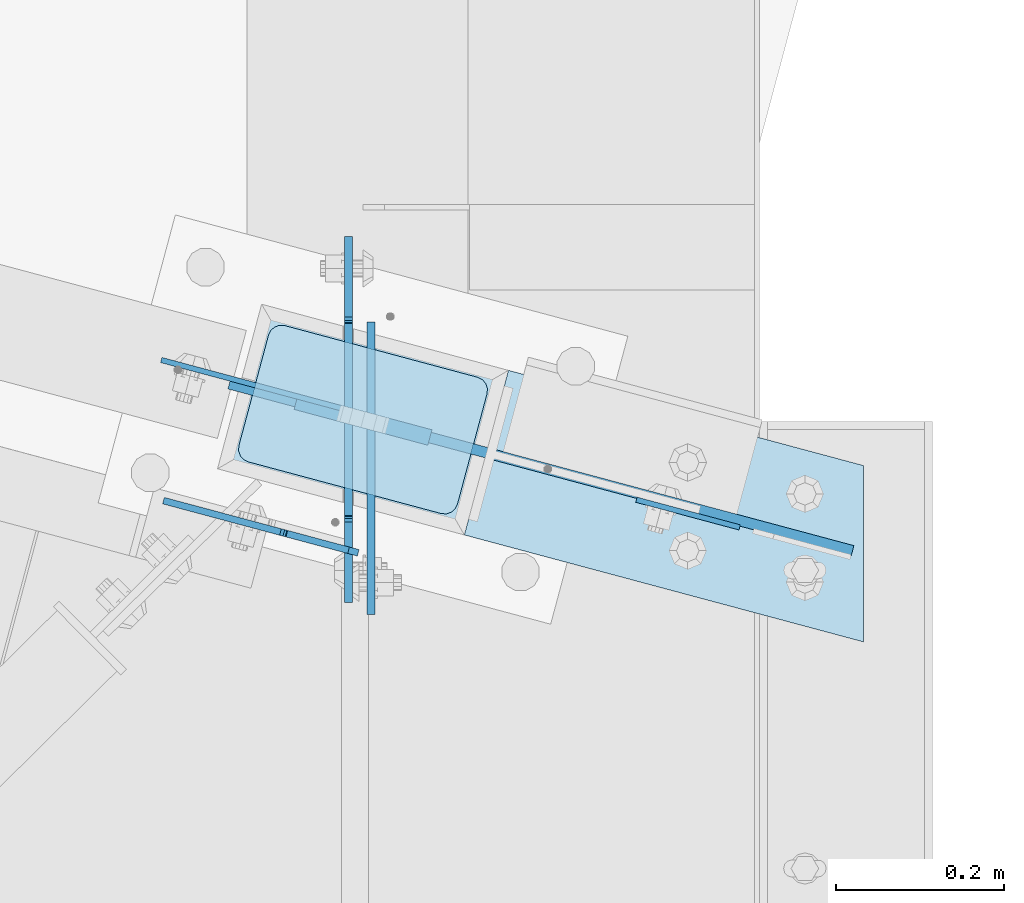
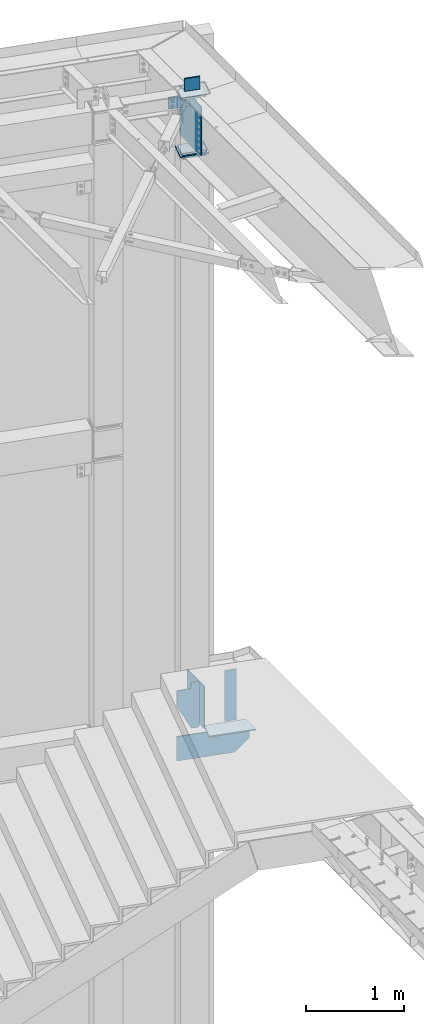
# One storey, part 1700 of 1763: 12 plates, 3 elements without a shape of their own.
"""IFC2X3 building model written with IfcOpenShell, lengths in millimetres."""

import ifcopenshell
import ifcopenshell.guid

model = None  # the IFC model being written
_history = None  # IfcOwnerHistory: only IFC2X3 demands one
_inside = {}  # id of a spatial element -> (the spatial element, [elements in it])
_under = {}  # id of a project, library or spatial element -> (it, [spatial elements below it])
_declared = {}  # id of a project -> (the project, [libraries it declares])
_typed = {}  # id of a type object -> (the type object, [elements of that type])
_made_of = {}  # id of a material, layer set ... -> (it, [elements and type objects made of it])


def new_model(schema):
    """Start an empty IFC model of exactly this schema.

    Asked for "IFC4X3", IfcOpenShell would pick the latest addendum, in which some entities
    have other attributes; the version numbers below select the first issue.
    IFC2X3 requires an IfcOwnerHistory on every rooted entity: one is made here for all.
    """
    global model, _history
    if schema == "IFC4X3":
        model = ifcopenshell.file(schema_version=(4, 3, 0, 0))
    else:
        model = ifcopenshell.file(schema=schema)
    _inside.clear()
    _under.clear()
    _declared.clear()
    _typed.clear()
    _made_of.clear()
    _history = None
    if model.schema == "IFC2X3":
        org = make("IfcOrganization", Name="unknown")
        user = make(
            "IfcPersonAndOrganization",
            ThePerson=make("IfcPerson", FamilyName="unknown"),
            TheOrganization=org,
        )
        app = make(
            "IfcApplication",
            ApplicationDeveloper=org,
            Version="unknown",
            ApplicationFullName="unknown",
            ApplicationIdentifier="unknown",
        )
        _history = make(
            "IfcOwnerHistory",
            OwningUser=user,
            OwningApplication=app,
            ChangeAction="ADDED",
            CreationDate=0,
        )
    return model


def make(cls, **values):
    """One entity of the class cls with the attributes given. An attribute that is None is left unset."""
    return model.create_entity(
        cls, **{name: value for name, value in values.items() if value is not None}
    )


def rooted(cls, **values):
    """An entity with a GlobalId (a new one), such as an element, a storey or a relation."""
    return make(cls, GlobalId=ifcopenshell.guid.new(), OwnerHistory=_history, **values)


def si_unit(unit_type, name, prefix=None):
    """IfcSIUnit, for example si_unit("LENGTHUNIT", "METRE", prefix="MILLI")."""
    return make("IfcSIUnit", UnitType=unit_type, Prefix=prefix, Name=name)


def assignment(units):
    """IfcUnitAssignment: the units of a project."""
    return None if units is None else make("IfcUnitAssignment", Units=units)


def point(xyz):
    """IfcCartesianPoint."""
    return None if xyz is None else make("IfcCartesianPoint", Coordinates=xyz)


def direction(xyz):
    """IfcDirection."""
    return None if xyz is None else make("IfcDirection", DirectionRatios=xyz)


def frame(location, z_axis=None, x_axis=None):
    """IfcAxis2Placement3D, a coordinate frame: its origin and axes. An axis left out is left unset."""
    return make(
        "IfcAxis2Placement3D",
        Location=point(location),
        Axis=direction(z_axis),
        RefDirection=direction(x_axis),
    )


def origin_with_axes():
    """The frame at (0, 0, 0) with the z axis (0, 0, 1) and the x axis (1, 0, 0) written out."""
    return frame((0.0, 0.0, 0.0), z_axis=(0.0, 0.0, 1.0), x_axis=(1.0, 0.0, 0.0))


def place(relative_to, where):
    """IfcLocalPlacement: puts the frame where relative to a parent placement (None: the world)."""
    return make(
        "IfcLocalPlacement", PlacementRelTo=relative_to, RelativePlacement=where
    )


def context(
    kind, dimensions, precision=None, world=None, true_north=None, identifier=None
):
    """IfcGeometricRepresentationContext, for example the 3D "Model" context."""
    return make(
        "IfcGeometricRepresentationContext",
        ContextIdentifier=identifier,
        ContextType=kind,
        CoordinateSpaceDimension=dimensions,
        Precision=precision,
        WorldCoordinateSystem=world,
        TrueNorth=true_north,
    )


def subcontext(parent, identifier, kind, view, scale=None):
    """IfcGeometricRepresentationSubContext, for example "Body" below "Model"."""
    return make(
        "IfcGeometricRepresentationSubContext",
        ContextIdentifier=identifier,
        ContextType=kind,
        ParentContext=parent,
        TargetScale=scale,
        TargetView=view,
    )


def project(units=None, contexts=None):
    """IfcProject with its units and contexts."""
    return rooted(
        "IfcProject",
        Name="project",
        RepresentationContexts=contexts,
        UnitsInContext=assignment(units),
    )


def spatial(cls, under=None, at=None, **own):
    """A site, building, storey or space (cls), placed at a placement, below another one or the project."""
    s = rooted(cls, ObjectPlacement=at, **own)
    if under is not None:
        _under.setdefault(under.id(), (under, []))[1].append(s)
    return s


def faces_of(points, faces, orient=None, outer=None):
    """IfcFace entities. A face is a list of loops; a loop is a list of indices into points, from 0.

    orient and outer hold one flag for each loop. By default every Orientation is true, the
    first loop of a face is its IfcFaceOuterBound and the others are IfcFaceBound.
    """
    made = []
    for i, loops in enumerate(faces):
        bounds = []
        for j, loop in enumerate(loops):
            is_outer = j == 0 if outer is None else outer[i][j]
            bounds.append(
                make(
                    "IfcFaceOuterBound" if is_outer else "IfcFaceBound",
                    Bound=make("IfcPolyLoop", Polygon=[points[k] for k in loop]),
                    Orientation=True if orient is None else orient[i][j],
                )
            )
        made.append(make("IfcFace", Bounds=bounds))
    return made


def faceted_brep(points, faces, orient=None, outer=None, voids=None):
    """IfcFacetedBrep: a solid bounded by flat faces; with voids (closed shells), ...WithVoids."""
    shared = [point(p) for p in points]
    hull = make("IfcClosedShell", CfsFaces=faces_of(shared, faces, orient, outer))
    if voids is None:
        return make("IfcFacetedBrep", Outer=hull)
    return make(
        "IfcFacetedBrepWithVoids",
        Outer=hull,
        Voids=[
            make(cls, CfsFaces=faces_of(shared, fs, o, b)) for cls, fs, o, b in voids
        ],
    )


def shape(context_of_items, identifier, shape_type, items):
    """IfcShapeRepresentation: the items that make up one representation, for example the "Body"."""
    return make(
        "IfcShapeRepresentation",
        ContextOfItems=context_of_items,
        RepresentationIdentifier=identifier,
        RepresentationType=shape_type,
        Items=items,
    )


def material(Name=None, Category=None):
    """IfcMaterial."""
    return make("IfcMaterial", Name=Name, Category=Category)


def made_of(thing, what):
    """Note that an element or type object is made of a material, layer set ...; save() writes the relation."""
    if what is not None:
        _made_of.setdefault(what.id(), (what, []))[1].append(thing)
    return thing


def type_object(cls, material=None, **own):
    """A type object (cls), such as IfcWallType, which elements share."""
    return made_of(rooted(cls, **own), material)


def element(
    cls,
    number,
    at=None,
    inside=None,
    cuts=None,
    type_object=None,
    material=None,
    context=None,
    identifier="Body",
    shape_type=None,
    held_by="IfcProductDefinitionShape",
    body=None,
    shapes=None,
    **own,
):
    """One element of the class cls, such as IfcWall. Its Tag is "e" and its number.

    at: its placement. inside: the storey or other place that contains it. cuts: it is an
    opening in that element (IfcRelVoidsElement). A single representation is given by context,
    identifier, shape_type and body (its items); several are given by shapes. held_by: the class
    of the entity that holds the representations. save() writes the other relations.
    """
    e = rooted(cls, Tag="e%d" % number, ObjectPlacement=at, **own)
    if body is not None:
        shapes = [shape(context, identifier, shape_type, body)]
    if shapes is not None:
        e.Representation = make(held_by, Representations=shapes)
    if inside is not None:
        _inside.setdefault(inside.id(), (inside, []))[1].append(e)
    if cuts is not None:
        rooted(
            "IfcRelVoidsElement", RelatingBuildingElement=cuts, RelatedOpeningElement=e
        )
    if type_object is not None:
        _typed.setdefault(type_object.id(), (type_object, []))[1].append(e)
    return made_of(e, material)


def aggregate(whole, parts):
    """IfcRelAggregates: a whole, such as a stair, and the parts it consists of."""
    return rooted("IfcRelAggregates", RelatingObject=whole, RelatedObjects=parts)


def save(model, path):
    """Write the relations noted so far, then the file.

    IfcRelAggregates (storeys below a building ...), IfcRelContainedInSpatialStructure (elements
    in a storey), IfcRelDefinesByType, IfcRelAssociatesMaterial and IfcRelDeclares: one each for
    every whole, place, type object, material and project.
    """
    for whole, parts in _under.values():
        aggregate(whole, parts)
    for where, things in _inside.values():
        rooted(
            "IfcRelContainedInSpatialStructure",
            RelatedElements=things,
            RelatingStructure=where,
        )
    for kind, things in _typed.values():
        rooted("IfcRelDefinesByType", RelatedObjects=things, RelatingType=kind)
    for what, things in _made_of.values():
        rooted("IfcRelAssociatesMaterial", RelatedObjects=things, RelatingMaterial=what)
    for by, libraries in _declared.values():
        rooted("IfcRelDeclares", RelatingContext=by, RelatedDefinitions=libraries)
    model.write(path)


model = new_model("IFC2X3")

# Units and contexts
model_context = context("Model", 3, precision=1e-05, world=origin_with_axes())
body_context = subcontext(model_context, "Body", "Model", "MODEL_VIEW")
ifc_project = project(units=[si_unit("LENGTHUNIT", "METRE", prefix="MILLI"), si_unit("AREAUNIT", "SQUARE_METRE"), si_unit("VOLUMEUNIT", "CUBIC_METRE"), si_unit("MASSUNIT", "GRAM", prefix="KILO"), si_unit("TIMEUNIT", "SECOND"), si_unit("PLANEANGLEUNIT", "RADIAN"), si_unit("SOLIDANGLEUNIT", "STERADIAN"), si_unit("THERMODYNAMICTEMPERATUREUNIT", "DEGREE_CELSIUS"), si_unit("LUMINOUSINTENSITYUNIT", "LUMEN")], contexts=[model_context])

# Site, building, storey
site_placement = place(None, origin_with_axes())
site = spatial("IfcSite", under=ifc_project, at=site_placement, CompositionType="ELEMENT")
building_placement = place(site_placement, origin_with_axes())
building = spatial("IfcBuilding", under=site, at=building_placement, Name="Undefined", CompositionType="ELEMENT")
storey_placement = place(building_placement, origin_with_axes())
storey = spatial("IfcBuildingStorey", under=building, at=storey_placement, Name="Undefined", CompositionType="ELEMENT", Elevation=0.0)

# Assembly, plates
assembly_1_placement = place(storey_placement, origin_with_axes())
assembly_1 = element("IfcElementAssembly", 1, at=assembly_1_placement, inside=storey, Name="COLUMN", AssemblyPlace="NOTDEFINED", PredefinedType="RIGID_FRAME")
ifc_material_1 = material(Name="STEEL/A36")
plate_type_1 = type_object("IfcPlateType", PredefinedType="NOTDEFINED")
plate_1_placement = place(assembly_1_placement, frame((-21772.2372022032, 61972.2103091752, 12417.425), z_axis=(0.965913267114843, -0.258865912030785, 0.0), x_axis=(-0.258865912030778, -0.965913267114844, 3.00823476209188e-08)))
plate_1 = element("IfcPlate", 2, at=plate_1_placement, type_object=plate_type_1, material=ifc_material_1, Name="PLATE", context=body_context, shape_type="Brep", body=[
    faceted_brep([(-2.18278728425503e-11, -12.7000000000007, 15.875), (-1.67347025126219e-10, -12.7000000000007, 253.999999999985), (-1.67347025126219e-10, 12.7000000000007, 253.999999999985), (-2.18278728425503e-11, 12.7000000000007, 15.875), (1.20841242121242, -12.7000000000007, 260.075099488779), (1.20841242121242, 12.7000000000007, 260.075099488779), (4.649679848495, -12.7000000000007, 265.225320151323), (4.649679848495, 12.7000000000007, 265.225320151323), (9.79990051103232, -12.7000000000007, 268.666587578606), (9.79990051103232, 12.7000000000007, 268.666587578606), (15.8749999998181, -12.7000000000007, 269.874999999993), (15.8749999998181, 12.7000000000007, 269.874999999993), (152.400009155084, -12.7000000000007, 269.875000000073), (152.400009155084, 12.7000000000007, 269.875000000073), (158.475108643877, -12.7000000000007, 268.6665875787), (158.475108643877, 12.7000000000007, 268.6665875787), (163.625329306422, -12.7000000000007, 265.225320151425), (163.625329306422, 12.7000000000007, 265.225320151425), (167.066596733705, -12.7000000000007, 260.07509948888), (167.066596733705, 12.7000000000007, 260.07509948888), (168.275009155092, -12.7000000000007, 254.000000000087), (168.275009155092, 12.7000000000007, 254.000000000087), (168.275009155237, -12.7000000000007, 15.8750000001019), (168.275009155237, 12.7000000000007, 15.8750000001019), (167.066596733865, -12.7000000000007, 9.79990051130881), (167.066596733865, 12.7000000000007, 9.79990051130881), (163.625329306582, -12.7000000000007, 4.64967984876421), (163.625329306582, 12.7000000000007, 4.64967984876421), (158.475108644045, -12.7000000000007, 1.20841242148163), (158.475108644045, 12.7000000000007, 1.20841242148163), (152.400000000001, -12.6999998092651, 0.0), (152.400000000001, 12.6999998092651, 0.0), (15.8749999999854, -12.7000000000007, 0.0), (15.8749999999854, 12.7000000000007, 0.0), (9.79990051119239, -12.7000000000007, 1.20841242137976), (9.79990051119239, 12.7000000000007, 1.20841242137976), (4.64967984864779, -12.7000000000007, 4.64967984866234), (4.64967984864779, 12.7000000000007, 4.64967984866234), (1.20841242136521, -12.7000000000007, 9.79990051119967), (1.20841242136521, 12.7000000000007, 9.79990051119967)], [[[0, 1, 2, 3]], [[1, 4, 5, 2]], [[4, 6, 7, 5]], [[6, 8, 9, 7]], [[8, 10, 11, 9]], [[10, 12, 13, 11]], [[12, 14, 15, 13]], [[14, 16, 17, 15]], [[16, 18, 19, 17]], [[18, 20, 21, 19]], [[20, 22, 23, 21]], [[22, 24, 25, 23]], [[24, 26, 27, 25]], [[26, 28, 29, 27]], [[28, 30, 31, 29]], [[30, 32, 33, 31]], [[32, 34, 35, 33]], [[34, 36, 37, 35]], [[36, 38, 39, 37]], [[38, 0, 3, 39]], [[5, 7, 9, 11, 13, 15, 17, 19, 21, 23, 25, 27, 29, 31, 33, 35, 37, 39, 3, 2]], [[38, 36, 34, 32, 30, 28, 26, 24, 22, 20, 18, 16, 14, 12, 10, 8, 6, 4, 1, 0]]]),
])
plate_2_placement = place(assembly_1_placement, frame((-21772.2372023623, 61972.2103092178, 11684.0), z_axis=(0.965913267114843, -0.258865912030785, 0.0), x_axis=(-0.258865912030778, -0.965913267114844, 3.00823476209188e-08)))
plate_2 = element("IfcPlate", 3, at=plate_2_placement, type_object=plate_type_1, material=ifc_material_1, Name="PLATE", context=body_context, shape_type="Brep", body=[
    faceted_brep([(-2.18278728425503e-11, -12.7000000000007, 15.875), (-1.67347025126219e-10, -12.7000000000007, 253.999999999985), (-1.67347025126219e-10, 12.7000000000007, 253.999999999985), (-2.18278728425503e-11, 12.7000000000007, 15.875), (1.20841242121242, -12.7000000000007, 260.075099488779), (1.20841242121242, 12.7000000000007, 260.075099488779), (4.649679848495, -12.7000000000007, 265.225320151323), (4.649679848495, 12.7000000000007, 265.225320151323), (9.79990051103232, -12.7000000000007, 268.666587578606), (9.79990051103232, 12.7000000000007, 268.666587578606), (15.8749999998181, -12.7000000000007, 269.874999999993), (15.8749999998181, 12.7000000000007, 269.874999999993), (152.400009155084, -12.7000000000007, 269.875000000073), (152.400009155084, 12.7000000000007, 269.875000000073), (158.475108643877, -12.7000000000007, 268.6665875787), (158.475108643877, 12.7000000000007, 268.6665875787), (163.625329306422, -12.7000000000007, 265.225320151425), (163.625329306422, 12.7000000000007, 265.225320151425), (167.066596733705, -12.7000000000007, 260.07509948888), (167.066596733705, 12.7000000000007, 260.07509948888), (168.275009155092, -12.7000000000007, 254.000000000087), (168.275009155092, 12.7000000000007, 254.000000000087), (168.275009155237, -12.7000000000007, 15.8750000001019), (168.275009155237, 12.7000000000007, 15.8750000001019), (167.066596733865, -12.7000000000007, 9.79990051130881), (167.066596733865, 12.7000000000007, 9.79990051130881), (163.625329306582, -12.7000000000007, 4.64967984876421), (163.625329306582, 12.7000000000007, 4.64967984876421), (158.475108644045, -12.7000000000007, 1.20841242148163), (158.475108644045, 12.7000000000007, 1.20841242148163), (152.400000000001, -12.6999998092651, 0.0), (152.400000000001, 12.6999998092651, 0.0), (15.8749999999854, -12.7000000000007, 0.0), (15.8749999999854, 12.7000000000007, 0.0), (9.79990051119239, -12.7000000000007, 1.20841242137976), (9.79990051119239, 12.7000000000007, 1.20841242137976), (4.64967984864779, -12.7000000000007, 4.64967984866234), (4.64967984864779, 12.7000000000007, 4.64967984866234), (1.20841242136521, -12.7000000000007, 9.79990051119967), (1.20841242136521, 12.7000000000007, 9.79990051119967)], [[[0, 1, 2, 3]], [[1, 4, 5, 2]], [[4, 6, 7, 5]], [[6, 8, 9, 7]], [[8, 10, 11, 9]], [[10, 12, 13, 11]], [[12, 14, 15, 13]], [[14, 16, 17, 15]], [[16, 18, 19, 17]], [[18, 20, 21, 19]], [[20, 22, 23, 21]], [[22, 24, 25, 23]], [[24, 26, 27, 25]], [[26, 28, 29, 27]], [[28, 30, 31, 29]], [[30, 32, 33, 31]], [[32, 34, 35, 33]], [[34, 36, 37, 35]], [[36, 38, 39, 37]], [[38, 0, 3, 39]], [[5, 7, 9, 11, 13, 15, 17, 19, 21, 23, 25, 27, 29, 31, 33, 35, 37, 39, 3, 2]], [[38, 36, 34, 32, 30, 28, 26, 24, 22, 20, 18, 16, 14, 12, 10, 8, 6, 4, 1, 0]]]),
])
plate_3_placement = place(assembly_1_placement, frame((-21772.2372022827, 61972.2103091965, 11725.275), z_axis=(0.965913267114843, -0.258865912030785, 0.0), x_axis=(-0.258865912030778, -0.965913267114844, 3.00823476209188e-08)))
plate_3 = element("IfcPlate", 4, at=plate_3_placement, type_object=plate_type_1, material=ifc_material_1, Name="PLATE", context=body_context, shape_type="Brep", body=[
    faceted_brep([(-2.18278728425503e-11, -12.7000000000007, 15.875), (-1.67347025126219e-10, -12.7000000000007, 253.999999999985), (-1.67347025126219e-10, 12.7000000000007, 253.999999999985), (-2.18278728425503e-11, 12.7000000000007, 15.875), (1.20841242121242, -12.7000000000007, 260.075099488779), (1.20841242121242, 12.7000000000007, 260.075099488779), (4.649679848495, -12.7000000000007, 265.225320151323), (4.649679848495, 12.7000000000007, 265.225320151323), (9.79990051103232, -12.7000000000007, 268.666587578606), (9.79990051103232, 12.7000000000007, 268.666587578606), (15.8749999998181, -12.7000000000007, 269.874999999993), (15.8749999998181, 12.7000000000007, 269.874999999993), (152.400009155084, -12.7000000000007, 269.875000000073), (152.400009155084, 12.7000000000007, 269.875000000073), (158.475108643877, -12.7000000000007, 268.6665875787), (158.475108643877, 12.7000000000007, 268.6665875787), (163.625329306422, -12.7000000000007, 265.225320151425), (163.625329306422, 12.7000000000007, 265.225320151425), (167.066596733705, -12.7000000000007, 260.07509948888), (167.066596733705, 12.7000000000007, 260.07509948888), (168.275009155092, -12.7000000000007, 254.000000000087), (168.275009155092, 12.7000000000007, 254.000000000087), (168.275009155237, -12.7000000000007, 15.8750000001019), (168.275009155237, 12.7000000000007, 15.8750000001019), (167.066596733865, -12.7000000000007, 9.79990051130881), (167.066596733865, 12.7000000000007, 9.79990051130881), (163.625329306582, -12.7000000000007, 4.64967984876421), (163.625329306582, 12.7000000000007, 4.64967984876421), (158.475108644045, -12.7000000000007, 1.20841242148163), (158.475108644045, 12.7000000000007, 1.20841242148163), (152.400000000001, -12.6999998092651, 0.0), (152.400000000001, 12.6999998092651, 0.0), (15.8749999999854, -12.7000000000007, 0.0), (15.8749999999854, 12.7000000000007, 0.0), (9.79990051119239, -12.7000000000007, 1.20841242137976), (9.79990051119239, 12.7000000000007, 1.20841242137976), (4.64967984864779, -12.7000000000007, 4.64967984866234), (4.64967984864779, 12.7000000000007, 4.64967984866234), (1.20841242136521, -12.7000000000007, 9.79990051119967), (1.20841242136521, 12.7000000000007, 9.79990051119967)], [[[0, 1, 2, 3]], [[1, 4, 5, 2]], [[4, 6, 7, 5]], [[6, 8, 9, 7]], [[8, 10, 11, 9]], [[10, 12, 13, 11]], [[12, 14, 15, 13]], [[14, 16, 17, 15]], [[16, 18, 19, 17]], [[18, 20, 21, 19]], [[20, 22, 23, 21]], [[22, 24, 25, 23]], [[24, 26, 27, 25]], [[26, 28, 29, 27]], [[28, 30, 31, 29]], [[30, 32, 33, 31]], [[32, 34, 35, 33]], [[34, 36, 37, 35]], [[36, 38, 39, 37]], [[38, 0, 3, 39]], [[5, 7, 9, 11, 13, 15, 17, 19, 21, 23, 25, 27, 29, 31, 33, 35, 37, 39, 3, 2]], [[38, 36, 34, 32, 30, 28, 26, 24, 22, 20, 18, 16, 14, 12, 10, 8, 6, 4, 1, 0]]]),
])
ifc_material_2 = material(Name="STEEL/A572-50")
plate_type_2 = type_object("IfcPlateType", PredefinedType="NOTDEFINED")
plate_4_placement = place(assembly_1_placement, frame((-21784.5840226164, 61993.5980171923, 11704.6375), z_axis=(0.965913267114843, -0.258865912030785, 0.0), x_axis=(-0.258865912030778, -0.965913267114844, 3.00823476209188e-08)))
plate_4 = element("IfcPlate", 5, at=plate_4_placement, type_object=plate_type_2, material=ifc_material_2, Name="PLATE", context=body_context, shape_type="Brep", body=[
    faceted_brep([(-7.27595761418343e-12, -7.9375, 0.0), (-1.96450855582952e-10, -7.9375, 304.799987792954), (-1.96450855582952e-10, 7.9375, 304.799987792954), (-7.27595761418343e-12, 7.9375, 0.0), (203.199996948031, -7.9375, 304.799987793078), (203.199996948031, 7.9375, 304.799987793078), (203.199996948228, -7.9375, 1.30967237055302e-10), (203.199996948228, 7.9375, 1.30967237055302e-10)], [[[0, 1, 2, 3]], [[1, 4, 5, 2]], [[4, 6, 7, 5]], [[6, 0, 3, 7]], [[5, 7, 3, 2]], [[6, 4, 1, 0]]]),
])
plate_type_3 = type_object("IfcPlateType", PredefinedType="NOTDEFINED")
plate_5_placement = place(assembly_1_placement, frame((-21066.7896174484, 61801.1548230587, 4425.95), z_axis=(-0.259022208946389, -0.965871365800091, 0.0), x_axis=(-0.965871365800091, 0.259022208946388, 0.0)))
plate_5 = element("IfcPlate", 6, at=plate_5_placement, type_object=plate_type_3, material=ifc_material_1, Name="PLATE", context=body_context, shape_type="Brep", body=[
    faceted_brep([(0.0, -6.34999999999491, 1.45519152283669e-11), (-54.4652900696528, -6.35000000000036, 203.096343994075), (-54.4652900696528, 6.35000000000036, 203.096343994075), (0.0, 6.34999999999491, -2.91038304567337e-11), (438.31124877913, -6.35000000000036, 203.199996946656), (438.31124877913, 6.35000000000036, 203.199996946656), (438.344116210857, -6.35000000000036, -8.36735125631094e-10), (438.344116210857, 6.35000000000036, -8.36735125631094e-10)], [[[0, 1, 2, 3]], [[1, 4, 5, 2]], [[4, 6, 7, 5]], [[6, 0, 3, 7]], [[5, 7, 3, 2]], [[6, 4, 1, 0]]]),
])
plate_type_4 = type_object("IfcPlateType", PredefinedType="NOTDEFINED")
plate_6_placement = place(assembly_1_placement, frame((-21823.1587323007, 61898.7423643675, 4419.6), z_axis=(0.965907400040121, -0.258887803010752, 0.0), x_axis=(0.0, 0.0, -1.0)))
plate_6 = element("IfcPlate", 7, at=plate_6_placement, type_object=plate_type_4, material=ifc_material_1, Name="PLATE", context=body_context, shape_type="Brep", body=[
    faceted_brep([(0.0, -6.34999999999491, 1.45519152283669e-11), (-2.12050508707762e-07, -6.34999999729916, 769.583618164055), (-2.12050508707762e-07, 6.35000000266882, 769.58361816407), (0.0, 6.34999999999491, -2.91038304567337e-11), (304.799987792969, -6.34999999998399, -5.0931703299284e-11), (304.799987792969, 6.34999999999127, -4.36557456851006e-11), (304.799987792969, -6.34999999783031, 617.184069997485), (152.400439968145, -6.34999999729916, 769.583618164055), (152.399535925687, 6.35000000266882, 769.58361816407), (304.799987792969, 6.35000000213768, 617.183165955037)], [[[0, 1, 2, 3]], [[4, 0, 3, 5]], [[1, 0, 4, 6, 7]], [[2, 1, 7, 8]], [[5, 3, 2, 8, 9]], [[4, 5, 9, 6]], [[8, 7, 6, 9]]]),
])
plate_type_5 = type_object("IfcPlateType", PredefinedType="NOTDEFINED")
plate_7_placement = place(assembly_1_placement, frame((-21583.9424361156, 61834.6445739549, 12611.0999938965), z_axis=(0.0, 0.0, -1.0), x_axis=(-0.965925827679309, 0.258819039914073, 0.0)))
plate_7 = element("IfcPlate", 8, at=plate_7_placement, type_object=plate_type_5, material=ifc_material_2, Name="PLATE", context=body_context, shape_type="Brep", body=[
    faceted_brep([(7.27595761418343e-12, 9.52500000000146, 155.574990844727), (-1.45519152283669e-11, 7.27595761418343e-12, 165.099990844727), (165.099990844727, 0.0, 165.099990844727), (165.099990844727, 9.52500000000146, 155.574990844727), (-3.63797880709171e-11, -9.5249999999869, 155.574990844727), (165.099990844727, -9.52500000000146, 155.574990844727), (0.0, 9.52500000000146, 0.0), (0.0, -9.52500000000146, 0.0), (165.099990844727, -9.52500000000146, 0.0), (165.099990844727, 9.52500000000146, 0.0)], [[[0, 1, 2, 3]], [[1, 4, 5, 2]], [[6, 7, 4, 1, 0]], [[5, 8, 9, 3, 2]], [[8, 7, 6, 9]], [[9, 6, 0, 3]], [[7, 8, 5, 4]]]),
])

# Assembly, plate
assembly_2_placement = place(storey_placement, origin_with_axes())
assembly_2 = element("IfcElementAssembly", 9, at=assembly_2_placement, inside=storey, Name="BEAM", AssemblyPlace="NOTDEFINED", PredefinedType="RIGID_FRAME")
plate_type_6 = type_object("IfcPlateType", PredefinedType="NOTDEFINED")
plate_8_placement = place(assembly_2_placement, frame((-21656.3824228495, 61693.5855062951, 5180.01249995455), z_axis=(-0.965913267114846, 0.258865912030774, 0.0), x_axis=(0.0, 0.0, -1.0)))
plate_8 = element("IfcPlate", 10, at=plate_8_placement, type_object=plate_type_6, material=ifc_material_1, Name="PLATE", context=body_context, shape_type="Brep", body=[
    faceted_brep([(0.0, 3.96900000001187, 25.3999996185303), (0.0, -3.96899999999005, 25.3999996185375), (0.0, -3.96899999993911, 101.599533081026), (0.0, 3.96900000005553, 101.599533081026), (63.4999971389771, -3.96899999993911, 101.599533081026), (63.4999971389771, 3.96900000005553, 101.599533081026), (68.3600766570225, -3.96899999993911, 102.566263003617), (68.3600766570225, 3.96900000005553, 102.566263003609), (72.4802531251762, -3.96899999993911, 105.319276904091), (72.4802531251762, 3.96900000005553, 105.319276904083), (75.2332670256546, -3.96899999993911, 109.439453372244), (75.2332670256546, 3.96900000006281, 109.439453372237), (76.1999969482422, -3.96899999993184, 114.299532890291), (76.1999969482422, 3.96900000006281, 114.299532890283), (76.1999969482422, -3.96899999983725, 253.908416747996), (76.1999969482422, 3.96900000015739, 253.908416748032), (279.399999998638, -3.96899999984453, 253.908416748018), (279.400000001418, 3.96900000015739, 253.908416748032), (571.499998825446, -3.96899999994639, 101.508417279452), (571.5, 3.96900000005553, 101.508417280558), (571.5, -3.96899999999005, 25.3999996185375), (571.5, 3.96900000001187, 25.3999996185303), (559.659326927287, -3.96899999999732, 13.5593265458228), (559.659326927293, 3.96899999999732, 13.5593265458228), (11.8406730727074, 3.96899999999732, 13.5593265458228), (11.840673072712, -3.96899999999732, 13.5593265458228)], [[[0, 1, 2, 3]], [[4, 5, 3, 2]], [[6, 7, 5, 4]], [[8, 9, 7, 6]], [[10, 11, 9, 8]], [[12, 13, 11, 10]], [[14, 15, 13, 12]], [[15, 14, 16, 17]], [[18, 19, 17, 16]], [[20, 21, 19, 18]], [[21, 20, 22, 23]], [[0, 3, 5, 7, 9, 11, 13, 15, 17, 19, 21, 23, 24]], [[1, 0, 24, 25]], [[20, 18, 16, 14, 12, 10, 8, 6, 4, 2, 1, 25, 22]], [[24, 23, 22, 25]]]),
])
aggregate(assembly_2, [plate_8])

# Plate
plate_type_7 = type_object("IfcPlateType", PredefinedType="NOTDEFINED")
plate_9_placement = place(assembly_1_placement, frame((-21809.2430638104, 61901.587675922, 12404.725), z_axis=(0.0, 0.0, -1.0), x_axis=(0.965925826295336, -0.25881904507913, 0.0)))
plate_9 = element("IfcPlate", 11, at=plate_9_placement, type_object=plate_type_7, material=ifc_material_1, Name="PLATE", context=body_context, shape_type="Brep", body=[
    faceted_brep([(1.81898940354586e-12, -3.17500000000291, 0.0), (-98.4251556395247, -3.17499999981374, 0.0), (-98.4251556395247, 3.17500000019936, 0.0), (-1.81898940354586e-12, 3.17499999997381, 0.0), (-98.4251556395247, -3.17499999981374, 152.399993896484), (-98.4251556395247, 3.17500000019936, 152.399993896484), (126.801597595047, -3.17500000025029, 152.399993896484), (126.80159759504, 3.17499999977736, 152.399993896484), (126.801597595047, -3.17500000025029, 0.0), (126.80159759504, 3.17499999977736, 0.0)], [[[0, 1, 2, 3]], [[1, 4, 5, 2]], [[4, 6, 7, 5]], [[6, 8, 9, 7]], [[8, 0, 3, 9]], [[5, 7, 9, 3, 2]], [[8, 6, 4, 1, 0]]]),
])

plate_type_8 = type_object("IfcPlateType", PredefinedType="NOTDEFINED")
plate_10_placement = place(assembly_1_placement, frame((-21681.1516179138, 61964.6017870711, 12404.725), z_axis=(0.0, 0.0, -1.0), x_axis=(0.0, -1.0, 0.0)))
plate_10 = element("IfcPlate", 12, at=plate_10_placement, type_object=plate_type_8, material=ifc_material_1, Name="PLATE", context=body_context, shape_type="Brep", body=[
    faceted_brep([(-109.759323120117, -4.76250000000073, 22.2250003814697), (-109.759323120117, 4.76250000000073, 22.2250003814697), (-18.7093534469604, 4.76250000000073, 22.2250003814697), (-18.7093534469604, -4.76250000000073, 22.2250003814697), (-13.849273928914, 4.76250000000073, 21.2582704588822), (-13.849273928914, -4.76250000000073, 21.2582704588822), (-9.72909746076039, 4.76250000000073, 18.5052565584047), (-9.72909746076039, -4.76250000000073, 18.5052565584047), (-6.9760835602865, 4.76250000000073, 14.385080090251), (-6.9760835602865, -4.76250000000073, 14.385080090251), (-6.00935363769531, -4.76250000000073, 9.52500057220459), (-6.00935363769531, 4.76250000000073, 9.52500057220459), (-6.00935363769531, 4.76250000000073, 0.0), (-6.00935363769531, -4.76250000000073, 0.0), (-109.759323120117, -4.76250000000073, 631.825012207031), (326.820831298828, -4.76250000000073, 631.825012207031), (326.820831298828, 4.76250000000073, 631.825012207031), (-109.759323120117, 4.76250000000073, 631.825012207031), (326.820831298828, -4.76250000000073, 22.2250003814697), (326.820831298828, 4.76250000000073, 22.2250003814697), (235.770861625671, -4.76250000000073, 22.2250003814697), (235.770861625671, 4.76250000000073, 22.2250003814697), (230.910782107625, -4.76250000000073, 21.2582704588822), (230.910782107625, 4.76250000000073, 21.2582704588822), (226.790605639471, -4.76250000000073, 18.5052565584047), (226.790605639471, 4.76250000000073, 18.5052565584047), (224.037591738997, -4.76250000000073, 14.385080090251), (224.037591738997, 4.76250000000073, 14.385080090251), (223.070861816406, -4.76250000000073, 9.52500057220459), (223.070861816406, 4.76250000000073, 9.52500057220459), (223.070861816406, -4.76250000000073, 0.0), (223.070861816406, 4.76250000000073, 0.0), (0.0, -4.76249999999982, 0.0), (0.0, 4.76249999999982, 0.0)], [[[0, 1, 2, 3]], [[3, 2, 4, 5]], [[5, 4, 6, 7]], [[7, 6, 8, 9]], [[10, 11, 12, 13]], [[9, 8, 11, 10]], [[14, 15, 16, 17]], [[15, 18, 19, 16]], [[18, 20, 21, 19]], [[20, 22, 23, 21]], [[22, 24, 25, 23]], [[24, 26, 27, 25]], [[26, 28, 29, 27]], [[28, 30, 31, 29]], [[30, 32, 33, 31]], [[33, 32, 13, 12]], [[6, 4, 2, 1, 17, 16, 19, 21, 23, 25, 27, 29, 31, 33, 12, 11, 8]], [[14, 17, 1, 0]], [[32, 30, 28, 26, 24, 22, 20, 18, 15, 14, 0, 3, 5, 7, 9, 10, 13]]]),
])

# Assembly, plate
assembly_3_placement = place(storey_placement, origin_with_axes())
assembly_3 = element("IfcElementAssembly", 13, at=assembly_3_placement, inside=storey, Name="BEAM", AssemblyPlace="NOTDEFINED", PredefinedType="RIGID_FRAME")
plate_type_9 = type_object("IfcPlateType", PredefinedType="NOTDEFINED")
plate_11_placement = place(assembly_3_placement, frame((-21214.4551204576, 61727.4155628671, 5156.19999999368), z_axis=(-0.965925827679309, 0.258819039914073, 0.0), x_axis=(0.0, 0.0, -1.0)))
plate_11 = element("IfcPlate", 14, at=plate_11_placement, type_object=plate_type_9, material=ifc_material_1, Name="PLATE", context=body_context, shape_type="Brep", body=[
    faceted_brep([(1.81898940354586e-12, -3.17500000000291, 0.0), (1.49229890666902e-07, -3.17499999977008, 127.448005676102), (1.49228071677499e-07, 3.17500000024302, 127.448005676102), (-1.81898940354586e-12, 3.17499999997381, 0.0), (635.000061035135, -3.17500000006112, 127.448005675011), (635.000061035134, 3.17499999995925, 127.448005675011), (635.000061035157, -3.17500000029395, -1.02591002359986e-09), (635.000061035155, 3.17499999971915, -1.02591002359986e-09)], [[[0, 1, 2, 3]], [[1, 4, 5, 2]], [[4, 6, 7, 5]], [[6, 0, 3, 7]], [[5, 7, 3, 2]], [[6, 4, 1, 0]]]),
])
aggregate(assembly_3, [plate_11])

# Plate
plate_type_10 = type_object("IfcPlateType", PredefinedType="NOTDEFINED")
plate_12_placement = place(assembly_1_placement, frame((-21654.1646174484, 61743.2009610157, 5156.2), z_axis=(0.0, 0.0, -1.0), x_axis=(0.0, 1.0, 0.0)))
plate_12 = element("IfcPlate", 15, at=plate_12_placement, type_object=plate_type_10, material=ifc_material_1, Name="PLATE", context=body_context, shape_type="Brep", body=[
    faceted_brep([(0.0, -4.76249999999982, 0.0), (-119.821823120117, -4.76250000000073, 0.0), (-119.821823120117, 4.76250000000073, 0.0), (0.0, 4.76249999999982, 0.0), (-119.821823120117, -4.76250000000073, 533.400024414062), (-119.821823120117, 4.76250000000073, 533.400024414062), (229.420852661133, -4.76250000000073, 533.400024414062), (229.420852661133, 4.76250000000073, 533.400024414062), (229.420852661133, -4.76250000000073, 0.0), (229.420852661133, 4.76250000000073, 0.0)], [[[0, 1, 2, 3]], [[1, 4, 5, 2]], [[4, 6, 7, 5]], [[6, 8, 9, 7]], [[8, 0, 3, 9]], [[5, 7, 9, 3, 2]], [[8, 6, 4, 1, 0]]]),
])

aggregate(assembly_1, [plate_5, plate_6, plate_1, plate_9, plate_10, plate_7, plate_2, plate_3, plate_4, plate_12])

save(model, "model.ifc")
